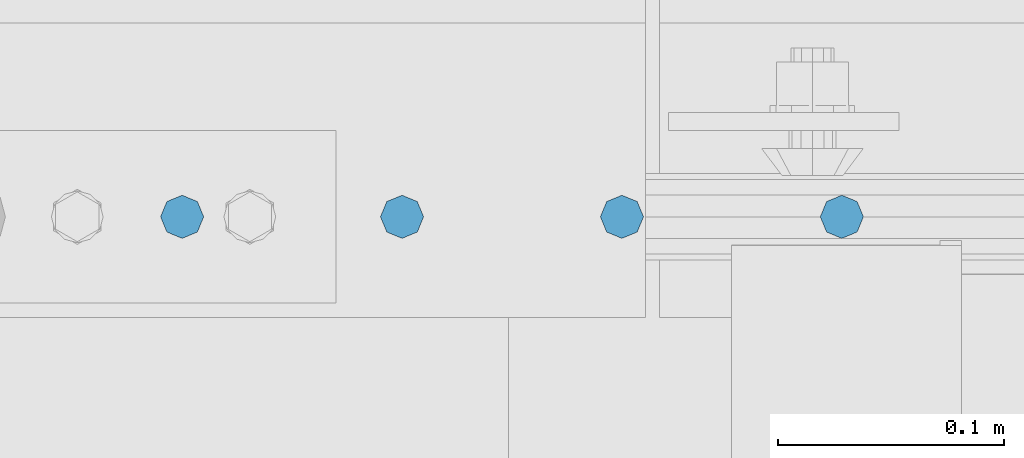
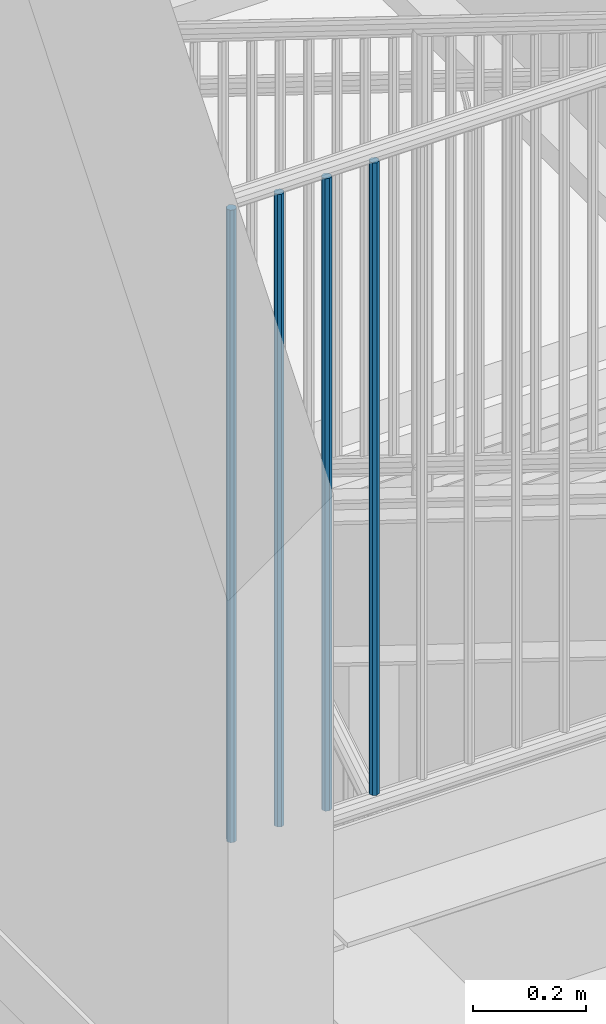
# One storey, part 1080 of 1763: 4 beams, 1 element without a shape of its own.
"""IFC2X3 building model written with IfcOpenShell, lengths in millimetres."""

from ifc_helpers import new_model, si_unit, frame, origin_with_axes, place, context, subcontext, project, spatial, faceted_brep, material, type_object, element, aggregate, save


model = new_model("IFC2X3")

# Units and contexts
model_context = context("Model", 3, precision=1e-05, world=origin_with_axes())
body_context = subcontext(model_context, "Body", "Model", "MODEL_VIEW")
ifc_project = project(units=[si_unit("LENGTHUNIT", "METRE", prefix="MILLI"), si_unit("AREAUNIT", "SQUARE_METRE"), si_unit("VOLUMEUNIT", "CUBIC_METRE"), si_unit("MASSUNIT", "GRAM", prefix="KILO"), si_unit("TIMEUNIT", "SECOND"), si_unit("PLANEANGLEUNIT", "RADIAN"), si_unit("SOLIDANGLEUNIT", "STERADIAN"), si_unit("THERMODYNAMICTEMPERATUREUNIT", "DEGREE_CELSIUS"), si_unit("LUMINOUSINTENSITYUNIT", "LUMEN")], contexts=[model_context])

# Site, building, storey
site_placement = place(None, origin_with_axes())
site = spatial("IfcSite", under=ifc_project, at=site_placement, CompositionType="ELEMENT")
building_placement = place(site_placement, origin_with_axes())
building = spatial("IfcBuilding", under=site, at=building_placement, Name="Undefined", CompositionType="ELEMENT")
storey_placement = place(building_placement, origin_with_axes())
storey = spatial("IfcBuildingStorey", under=building, at=storey_placement, Name="Undefined", CompositionType="ELEMENT", Elevation=0.0)

# Assembly, beams
assembly_placement = place(storey_placement, origin_with_axes())
assembly = element("IfcElementAssembly", 1, at=assembly_placement, inside=storey, Name="RAIL", AssemblyPlace="NOTDEFINED", PredefinedType="RIGID_FRAME")
ifc_material = material(Name="STEEL/A36")
beam_type = type_object("IfcBeamType", PredefinedType="NOTDEFINED")
beam_1_placement = place(assembly_placement, frame((-87583.1324748173, 31673.7999996711, 6858.00000000561), z_axis=(0.0, -1.0, 0.0), x_axis=(0.0, 0.0, -1.0)))
beam_1 = element("IfcBeam", 2, at=beam_1_placement, type_object=beam_type, material=ifc_material, Name="PICKET", context=body_context, shape_type="Brep", body=[
    faceted_brep([(19.0499999999092, -9.52500000000146, 0.0), (19.0499999999092, -6.73519209080405, -6.73519209079677), (1384.29999999477, -6.73519209082588, -6.73519209079677), (1384.29999999477, -9.52499999999418, 3.63797880709171e-12), (19.0499999999092, 0.0, -9.52499999999418), (1384.29999999477, -4.36557456851006e-11, -9.52500000000146), (19.0499999999092, 6.73519209080405, -6.73519209079677), (1384.29999999477, 6.73519209078222, -6.73519209080769), (19.0499999999092, 9.52500000000146, 0.0), (1384.29999999477, 9.52499999999418, -3.63797880709171e-12), (19.0499999999092, 6.73519209080405, 6.73519209079677), (1384.29999999477, 6.73519209082588, 6.73519209079677), (19.0499999999092, 0.0, 9.52499999999418), (1384.29999999477, 2.91038304567337e-11, 9.52500000000146), (19.0499999999092, -6.73519209080405, 6.73519209079677), (1384.29999999477, -6.73519209078222, 6.73519209080769)], [[[0, 1, 2, 3]], [[1, 4, 5, 2]], [[4, 6, 7, 5]], [[6, 8, 9, 7]], [[8, 10, 11, 9]], [[10, 12, 13, 11]], [[12, 14, 15, 13]], [[14, 0, 3, 15]], [[5, 7, 9, 11, 13, 15, 3, 2]], [[14, 12, 10, 8, 6, 4, 1, 0]]]),
])
beam_2_placement = place(assembly_placement, frame((-87486.0276759361, 31673.7999997487, 6857.99999999773), z_axis=(0.0, -1.0, 0.0), x_axis=(0.0, 0.0, -1.0)))
beam_2 = element("IfcBeam", 3, at=beam_2_placement, type_object=beam_type, material=ifc_material, Name="PICKET", context=body_context, shape_type="Brep", body=[
    faceted_brep([(19.0499999999092, -9.52500000000146, 0.0), (19.0499999999092, -6.73519209080405, -6.73519209079677), (1384.29999999477, -6.73519209082588, -6.73519209079677), (1384.29999999477, -9.52499999999418, 3.63797880709171e-12), (19.0499999999092, 0.0, -9.52499999999418), (1384.29999999477, -4.36557456851006e-11, -9.52500000000146), (19.0499999999092, 6.73519209080405, -6.73519209079677), (1384.29999999477, 6.73519209078222, -6.73519209080769), (19.0499999999092, 9.52500000000146, 0.0), (1384.29999999477, 9.52499999999418, -3.63797880709171e-12), (19.0499999999092, 6.73519209080405, 6.73519209079677), (1384.29999999477, 6.73519209082588, 6.73519209079677), (19.0499999999092, 0.0, 9.52499999999418), (1384.29999999477, 2.91038304567337e-11, 9.52500000000146), (19.0499999999092, -6.73519209080405, 6.73519209079677), (1384.29999999477, -6.73519209078222, 6.73519209080769)], [[[0, 1, 2, 3]], [[1, 4, 5, 2]], [[4, 6, 7, 5]], [[6, 8, 9, 7]], [[8, 10, 11, 9]], [[10, 12, 13, 11]], [[12, 14, 15, 13]], [[14, 0, 3, 15]], [[5, 7, 9, 11, 13, 15, 3, 2]], [[14, 12, 10, 8, 6, 4, 1, 0]]]),
])
beam_3_placement = place(assembly_placement, frame((-87388.9228770548, 31673.7999998262, 6857.99999998984), z_axis=(0.0, -1.0, 0.0), x_axis=(0.0, 0.0, -1.0)))
beam_3 = element("IfcBeam", 4, at=beam_3_placement, type_object=beam_type, material=ifc_material, Name="PICKET", context=body_context, shape_type="Brep", body=[
    faceted_brep([(19.0499999999092, -9.52500000000146, 0.0), (19.0499999999092, -6.73519209080405, -6.73519209079677), (1384.29999999477, -6.73519209082588, -6.73519209079677), (1384.29999999477, -9.52499999999418, 3.63797880709171e-12), (19.0499999999092, 0.0, -9.52499999999418), (1384.29999999477, -4.36557456851006e-11, -9.52500000000146), (19.0499999999092, 6.73519209080405, -6.73519209079677), (1384.29999999477, 6.73519209078222, -6.73519209080769), (19.0499999999092, 9.52500000000146, 0.0), (1384.29999999477, 9.52499999999418, -3.63797880709171e-12), (19.0499999999092, 6.73519209080405, 6.73519209079677), (1384.29999999477, 6.73519209082588, 6.73519209079677), (19.0499999999092, 0.0, 9.52499999999418), (1384.29999999477, 2.91038304567337e-11, 9.52500000000146), (19.0499999999092, -6.73519209080405, 6.73519209079677), (1384.29999999477, -6.73519209078222, 6.73519209080769)], [[[0, 1, 2, 3]], [[1, 4, 5, 2]], [[4, 6, 7, 5]], [[6, 8, 9, 7]], [[8, 10, 11, 9]], [[10, 12, 13, 11]], [[12, 14, 15, 13]], [[14, 0, 3, 15]], [[5, 7, 9, 11, 13, 15, 3, 2]], [[14, 12, 10, 8, 6, 4, 1, 0]]]),
])
beam_4_placement = place(assembly_placement, frame((-87291.8180781736, 31673.7999999037, 6857.99999998195), z_axis=(0.0, -1.0, 0.0), x_axis=(0.0, 0.0, -1.0)))
beam_4 = element("IfcBeam", 5, at=beam_4_placement, type_object=beam_type, material=ifc_material, Name="PICKET", context=body_context, shape_type="Brep", body=[
    faceted_brep([(19.0499999999092, -9.52500000000146, 0.0), (19.0499999999092, -6.73519209080405, -6.73519209079677), (1384.29999999477, -6.73519209082588, -6.73519209079677), (1384.29999999477, -9.52499999999418, 3.63797880709171e-12), (19.0499999999092, 0.0, -9.52499999999418), (1384.29999999477, -4.36557456851006e-11, -9.52500000000146), (19.0499999999092, 6.73519209080405, -6.73519209079677), (1384.29999999477, 6.73519209078222, -6.73519209080769), (19.0499999999092, 9.52500000000146, 0.0), (1384.29999999477, 9.52499999999418, -3.63797880709171e-12), (19.0499999999092, 6.73519209080405, 6.73519209079677), (1384.29999999477, 6.73519209082588, 6.73519209079677), (19.0499999999092, 0.0, 9.52499999999418), (1384.29999999477, 2.91038304567337e-11, 9.52500000000146), (19.0499999999092, -6.73519209080405, 6.73519209079677), (1384.29999999477, -6.73519209078222, 6.73519209080769)], [[[0, 1, 2, 3]], [[1, 4, 5, 2]], [[4, 6, 7, 5]], [[6, 8, 9, 7]], [[8, 10, 11, 9]], [[10, 12, 13, 11]], [[12, 14, 15, 13]], [[14, 0, 3, 15]], [[5, 7, 9, 11, 13, 15, 3, 2]], [[14, 12, 10, 8, 6, 4, 1, 0]]]),
])
aggregate(assembly, [beam_1, beam_2, beam_3, beam_4])

save(model, "model.ifc")
